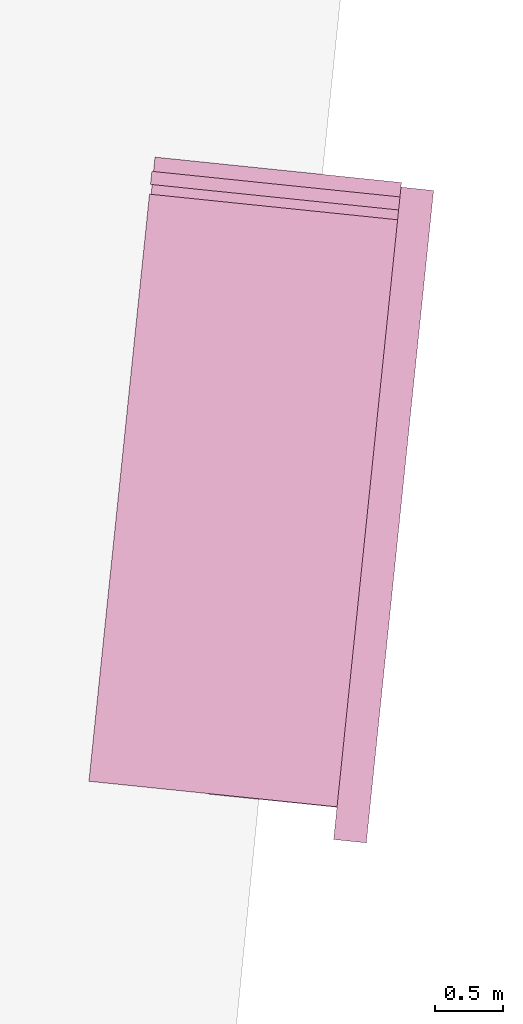
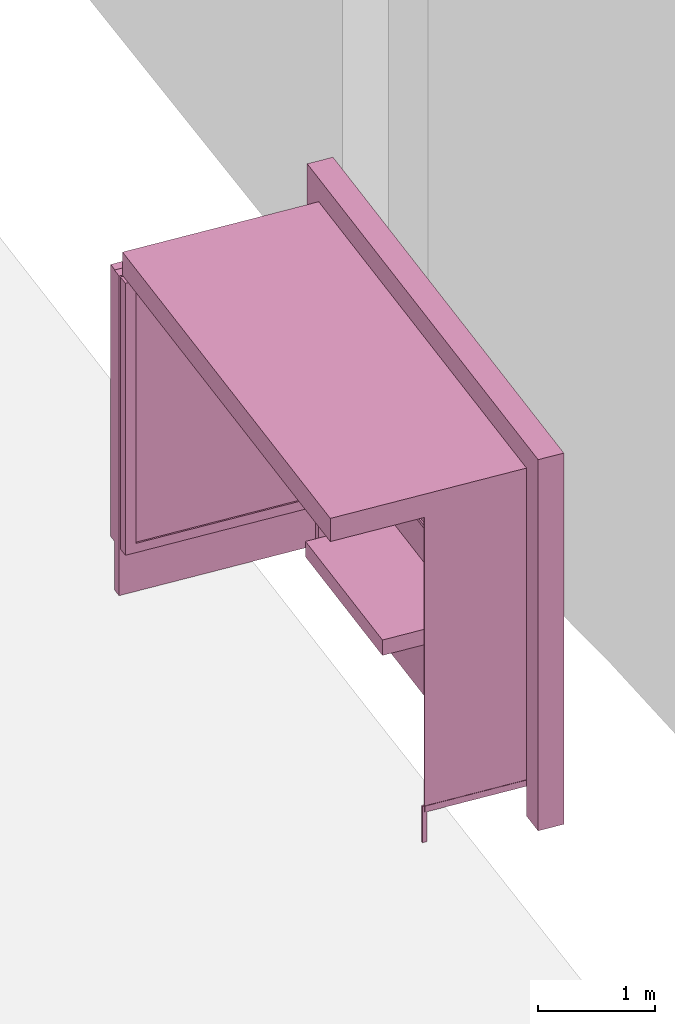
# One storey, part 12 of 200: 1 furnishing.
"""IFC4 building model written with IfcOpenShell, lengths in metres."""

from ifc_helpers import new_model, si_unit, origin_with_axes, place, context, subcontext, project, spatial, triangles, material, element, save


model = new_model("IFC4")

# Units and contexts
model_context = context("Model", 3, precision=1e-05, world=origin_with_axes())
body_context = subcontext(model_context, "Body", "Model", "MODEL_VIEW")
ifc_project = project(units=[si_unit("VOLUMEUNIT", "CUBIC_METRE"), si_unit("LENGTHUNIT", "METRE"), si_unit("AREAUNIT", "SQUARE_METRE")], contexts=[model_context])

# Site, building, storey
site_placement = place(None, origin_with_axes())
site = spatial("IfcSite", under=ifc_project, at=site_placement)
building_placement = place(site_placement, origin_with_axes())
building = spatial("IfcBuilding", under=site, at=building_placement, Name="Building")
storey_placement = place(building_placement, origin_with_axes())
storey = spatial("IfcBuildingStorey", under=building, at=storey_placement, Name="Ground")

# Furnishing
ifc_material = material(Name="busStop")
furnishing_placement = place(storey_placement, origin_with_axes())
element("IfcFurnishingElement", 1, at=furnishing_placement, inside=storey, material=ifc_material, Name="cw_instances_busStop_31", context=body_context, shape_type="Tessellation", body=[
    triangles([(370.17705950361335, -660.5963366665247, 3.3826375611235573), (371.7952975416118, -665.1250745815855, 3.3826375611235573), (372.2406078462146, -660.8092568819388, 3.3826375611235573), (369.7317489730696, -664.9121545205603, 3.3826375611235573), (370.1770594077063, -660.596336656629, 3.6236783199298275), (371.7952974457047, -665.1250745716898, 3.6236783199298275), (369.73174887716254, -664.9121545106645, 3.6236783199298275), (372.2406077503075, -660.8092568720431, 3.6236783199298275), (370.17705950361335, -660.5963366665247, 3.3826375611235573), (369.73174887716254, -664.9121545106645, 3.6236783199298275), (369.7317489730696, -664.9121545205603, 3.3826375611235573), (370.1770594077063, -660.596336656629, 3.6236783199298275), (369.7317489730696, -664.9121545205603, 3.3826375611235573), (371.7952974457047, -665.1250745716898, 3.6236783199298275), (371.7952975416118, -665.1250745815855, 3.3826375611235573), (369.73174887716254, -664.9121545106645, 3.6236783199298275), (371.7952975416118, -665.1250745815855, 3.3826375611235573), (372.2406077503075, -660.8092568720431, 3.6236783199298275), (372.2406078462146, -660.8092568819388, 3.3826375611235573), (371.7952974457047, -665.1250745716898, 3.6236783199298275), (372.2406078462146, -660.8092568819388, 3.3826375611235573), (370.1770594077063, -660.596336656629, 3.6236783199298275), (370.17705950361335, -660.5963366665247, 3.3826375611235573), (372.2406077503075, -660.8092568720431, 3.6236783199298275), (372.0008397530302, -660.7845174277934, 3.864718677001767), (372.26534680877126, -660.5694890126616, 3.864718677001767), (372.24060738266377, -660.8092568341093, 3.864718677001767), (372.02557917913765, -660.5447496063457, 3.864718677001767), (372.0008397530302, -660.7845174277934, 3.6236783199298275), (372.02557917913765, -660.5447496063457, 3.864718677001767), (372.0008397530302, -660.7845174277934, 3.864718677001767), (372.02557917913765, -660.5447496063457, 3.6236783199298275), (371.5307898359621, -665.3401027196483, 3.6236783199298275), (371.77055765740977, -665.3648421457558, 3.864718677001767), (371.77055765740977, -665.3648421457558, 3.6236783199298275), (371.5307898359621, -665.3401027196483, 3.864718677001767), (371.79529706207643, -665.1250745321067, 3.6236783199298275), (371.77055765740977, -665.3648421457558, 3.864718677001767), (371.79529706207643, -665.1250745321067, 3.864718677001767), (371.77055765740977, -665.3648421457558, 3.6236783199298275), (372.26534698460085, -660.5694890308039, 3.6236783199298275), (372.02557917913765, -660.5447496063457, 3.864718677001767), (372.02557917913765, -660.5447496063457, 3.6236783199298275), (372.26534680877126, -660.5694890126616, 3.864718677001767), (371.5555294324429, -665.1003351257908, 3.864718677001767), (371.79529706207643, -665.1250745321067, 3.864718677001767), (371.5555294324429, -665.1003351257908, 3.6236783199298275), (371.5555294324429, -665.1003351257908, 3.864718677001767), (372.26534698460085, -660.5694890308039, 3.6236783199298275), (372.24060738266377, -660.8092568341093, 3.864718677001767), (372.26534680877126, -660.5694890126616, 3.864718677001767), (372.24060738266377, -660.8092568341093, 3.6236783199298275), (371.5307898359621, -665.3401027196483, 3.864718677001767), (371.77055765740977, -665.3648421457558, 3.864718677001767), (371.5307898359621, -665.3401027196483, 3.6236783199298275), (371.5307898359621, -665.3401027196483, 3.864718677001767), (372.2653478477645, -660.5694891198657, 9.480930192426488e-07), (372.02558031403794, -660.5447497234455, 8.998848996201414e-07), (372.240608421657, -660.8092569413135, 9.480930192426488e-07), (372.2653478477645, -660.5694891198657, 9.480930192426488e-07), (372.24060738266377, -660.8092568341093, 3.6236783199298275), (372.00084071210085, -660.7845175267511, 8.998848996201414e-07), (372.0008397530302, -660.7845174277934, 3.6236783199298275), (372.240608421657, -660.8092569413135, 9.480930192426488e-07), (372.02558031403794, -660.5447497234455, 8.998848996201414e-07), (372.00084071210085, -660.7845175267511, 8.998848996201414e-07), (371.53079114352977, -665.340101319869, 8.998848996201414e-07), (371.770558696403, -665.3648422529599, 9.480930192426488e-07), (371.55553054984574, -665.1003336902354, 8.998848996201414e-07), (371.53079114352977, -665.340101319869, 8.998848996201414e-07), (371.5555294324429, -665.1003351257908, 3.6236783199298275), (371.7952982594018, -665.1250731047978, 9.480930192426488e-07), (371.79529706207643, -665.1250745321067, 3.6236783199298275), (371.55553054984574, -665.1003336902354, 8.998848996201414e-07), (371.770558696403, -665.3648422529599, 9.480930192426488e-07), (371.7952982594018, -665.1250731047978, 9.480930192426488e-07), (370.60916941161054, -665.0024370793218, 0.3459945917589383), (371.6499156172004, -665.1098220640723, 3.3826375611235573), (371.649916480364, -665.1098221531342, 0.34599476852204364), (370.6091686283695, -665.0024369985064, 3.3826375611235573), (371.651565772689, -665.0938376583453, 0.34599476852204364), (370.6108179206945, -664.9864525037174, 3.3826375611235573), (370.61081870393554, -664.9864525845328, 0.3459945917589383), (371.65156490952546, -665.0938375692833, 3.3826375611235573), (370.61081870393554, -664.9864525845328, 0.3459945917589383), (370.6091686283695, -665.0024369985064, 3.3826375611235573), (370.60916941161054, -665.0024370793218, 0.3459945917589383), (370.6108179206945, -664.9864525037174, 3.3826375611235573), (371.6519781060784, -665.0898414347448, 0.313856054245785), (370.60875714596625, -665.006433116056, 0.3138558614133065), (371.6495041667662, -665.1138181849205, 0.313856054245785), (370.6112310852784, -664.9824563658802, 0.3138558614133065), (371.6519781060784, -665.0898414347448, 0.37813349886767544), (370.6087571299817, -665.0064331144067, 0.37813330603519696), (370.6112310692939, -664.982456364231, 0.37813330603519696), (371.6495041667662, -665.1138181849205, 0.37813349886767544), (371.6519781060784, -665.0898414347448, 0.313856054245785), (370.6112310692939, -664.982456364231, 0.37813330603519696), (370.6112310852784, -664.9824563658802, 0.3138558614133065), (371.6519781060784, -665.0898414347448, 0.37813349886767544), (370.60875714596625, -665.006433116056, 0.3138558614133065), (371.6495041667662, -665.1138181849205, 0.37813349886767544), (371.6495041667662, -665.1138181849205, 0.313856054245785), (370.6087571299817, -665.0064331144067, 0.37813330603519696), (370.6087571299817, -665.0064331144067, 0.37813330603519696), (370.6112310852784, -664.9824563658802, 0.3138558614133065), (370.6112310692939, -664.982456364231, 0.37813330603519696), (370.60875714596625, -665.006433116056, 0.3138558614133065), (370.58883727865003, -664.983896809399, 0.37813330603519696), (370.631150969224, -665.0049909457017, 0.37813330603519696), (370.5871294347396, -665.000448770305, 0.37813330603519696), (370.63285881313436, -664.9884389847957, 0.37813330603519696), (370.58883753440216, -664.9838968357876, 1.446243588675227e-07), (370.5871294347396, -665.000448770305, 0.37813330603519696), (370.5871296904918, -665.0004487966936, 1.446243588675227e-07), (370.58883727865003, -664.983896809399, 0.37813330603519696), (370.5871296904918, -665.0004487966936, 1.446243588675227e-07), (370.631150969224, -665.0049909457017, 0.37813330603519696), (370.63115108111555, -665.0049909572467, 1.6069373207502523e-07), (370.5871294347396, -665.000448770305, 0.37813330603519696), (370.63115108111555, -665.0049909572467, 1.6069373207502523e-07), (370.63285881313436, -664.9884389847957, 0.37813330603519696), (370.63285892502597, -664.9884389963407, 1.6069373207502523e-07), (370.631150969224, -665.0049909457017, 0.37813330603519696), (370.63285892502597, -664.9884389963407, 1.6069373207502523e-07), (370.58883727865003, -664.983896809399, 0.37813330603519696), (370.58883753440216, -664.9838968357876, 1.446243588675227e-07), (370.63285881313436, -664.9884389847957, 0.37813330603519696), (371.80125470557203, -662.0774311563895, 1.1248564780513874), (371.7889513152917, -663.6916303011961, 1.1248565744676267), (371.63632482860646, -663.6758821842612, 1.1248564780513874), (371.9538810004431, -662.0931792535329, 1.1248565744676267), (371.63632502042054, -663.6758822040528, 4.981505694325782e-07), (371.80125470557203, -662.0774311563895, 0.964162810253855), (371.63632482860646, -663.6758821842612, 0.964162810253855), (371.80125504124675, -662.0774311910246, 4.981505694325782e-07), (371.7889516989199, -663.6916303407792, 5.302893158475833e-07), (371.63632482860646, -663.6758821842612, 0.964162810253855), (371.7889513152917, -663.6916303011961, 0.9641629066700942), (371.63632502042054, -663.6758822040528, 4.981505694325782e-07), (371.9538813840714, -662.0931792931159, 5.302893158475833e-07), (371.7889513152917, -663.6916303011961, 0.9641629066700942), (371.9538810004431, -662.0931792535329, 0.9641629066700942), (371.7889516989199, -663.6916303407792, 5.302893158475833e-07), (371.80125504124675, -662.0774311910246, 4.981505694325782e-07), (371.9538810004431, -662.0931792535329, 0.9641629066700942), (371.80125470557203, -662.0774311563895, 0.964162810253855), (371.9538813840714, -662.0931792931159, 5.302893158475833e-07), (370.99694446160424, -663.6099104318863, 1.124856381635148), (371.1618742586473, -662.011459395768, 0.9641627138376155), (371.16187422667826, -662.0114593924694, 1.124856381635148), (370.9969444775887, -663.6099104335356, 0.9641627138376155), (371.7889513152917, -663.6916303011961, 1.1248565744676267), (371.63632482860646, -663.6758821842612, 1.1248564780513874), (371.9538810004431, -662.0931792535329, 1.1248565744676267), (371.7889513152917, -663.6916303011961, 1.1248565744676267), (371.80125470557203, -662.0774311563895, 1.1248564780513874), (371.9538810004431, -662.0931792535329, 1.1248565744676267), (371.16187422667826, -662.0114593924694, 1.124856381635148), (370.99694446160424, -663.6099104318863, 1.124856381635148), (371.1618742586473, -662.011459395768, 0.9641627138376155), (371.16187422667826, -662.0114593924694, 1.124856381635148), (370.99694446160424, -663.6099104318863, 1.124856381635148), (370.9969444775887, -663.6099104335356, 0.9641627138376155), (372.101544433871, -660.6544931834381, 0.34599476852204364), (371.6295278530457, -665.2291305500545, 3.503157940526693), (371.62952879613186, -665.2291306473629, 0.34599476852204364), (372.1015437625216, -660.6544931141677, 3.503157940526693), (371.6455133069054, -665.2307799413372, 0.34599476852204364), (372.1175282573106, -660.6561424064928, 3.503157940526693), (372.11752892866, -660.6561424757631, 0.34599476852204364), (371.6455123478347, -665.2307798423795, 3.503157940526693), (371.93149742930837, -660.5171735622599, 0.5810001600002933), (370.31172368593536, -660.3500440759383, 3.2193552137185355), (370.3117242613777, -660.3500441353129, 0.5809998707515756), (371.9314968218969, -660.5171734995868, 3.2193552137185355), (372.0290537862744, -660.5110848313168, 0.4845839046859049), (370.3133735537027, -660.334059640524, 0.5809998707515756), (370.2174667416517, -660.3241623680453, 0.48458358329844076), (371.93314672163336, -660.5011890674709, 0.5810001600002933), (370.31337297826036, -660.3340595811493, 3.2193552137185355), (370.2174657218052, -660.3241637975119, 3.3157713565473115), (371.9331461142219, -660.5011890047978, 3.2193552137185355), (372.02905313090946, -660.5110847636957, 3.3157713565473115), (371.93314672163336, -660.5011890674709, 0.5810001600002933), (370.3117242613777, -660.3500441353129, 0.5809998707515756), (370.3133735537027, -660.334059640524, 0.5809998707515756), (371.93149742930837, -660.5171735622599, 0.5810001600002933), (370.3133735537027, -660.334059640524, 0.5809998707515756), (370.31172368593536, -660.3500440759383, 3.2193552137185355), (370.31337297826036, -660.3340595811493, 3.2193552137185355), (370.3117242613777, -660.3500441353129, 0.5809998707515756), (370.31337297826036, -660.3340595811493, 3.2193552137185355), (371.9314968218969, -660.5171734995868, 3.2193552137185355), (371.9331461142219, -660.5011890047978, 3.2193552137185355), (370.31172368593536, -660.3500440759383, 3.2193552137185355), (371.9331461142219, -660.5011890047978, 3.2193552137185355), (371.93149742930837, -660.5171735622599, 0.5810001600002933), (371.93314672163336, -660.5011890674709, 0.5810001600002933), (371.9314968218969, -660.5171734995868, 3.2193552137185355), (370.1857791594107, -660.6312613834257, 3.3157713565473115), (372.02905313090946, -660.5110847636957, 3.3157713565473115), (371.99736628079376, -660.8181823199221, 3.3157713565473115), (370.2174657218052, -660.3241637975119, 3.3157713565473115), (370.18578002257425, -660.6312614724876, 0.48458358329844076), (370.2174657218052, -660.3241637975119, 3.3157713565473115), (370.1857791594107, -660.6312613834257, 3.3157713565473115), (370.2174667416517, -660.3241623680453, 0.48458358329844076), (372.0290537862744, -660.5110848313168, 0.4845839046859049), (371.99736628079376, -660.8181823199221, 3.3157713565473115), (372.02905313090946, -660.5110847636957, 3.3157713565473115), (371.99736704805025, -660.8181823990883, 0.4845839046859049), (371.90310930770323, -660.7923021437521, 0.5810001600002933), (370.28333570819086, -660.6251726722741, 3.2193552137185355), (371.9031085084777, -660.7923020612874, 3.2193552137185355), (370.2833362836332, -660.6251727316486, 0.5809998707515756), (371.99736704805025, -660.8181823990883, 0.4845839046859049), (370.2816869913082, -660.6411572264376, 0.5809998707515756), (371.90146001537823, -660.8082866385411, 0.5810001600002933), (370.18578002257425, -660.6312614724876, 0.48458358329844076), (370.28168641586586, -660.641157167063, 3.2193552137185355), (370.1857791594107, -660.6312613834257, 3.3157713565473115), (371.9014592161527, -660.8082865560764, 3.2193552137185355), (371.99736628079376, -660.8181823199221, 3.3157713565473115), (371.90146001537823, -660.8082866385411, 0.5810001600002933), (370.2833362836332, -660.6251727316486, 0.5809998707515756), (371.90310930770323, -660.7923021437521, 0.5810001600002933), (370.2816869913082, -660.6411572264376, 0.5809998707515756), (370.2816869913082, -660.6411572264376, 0.5809998707515756), (370.28333570819086, -660.6251726722741, 3.2193552137185355), (370.2833362836332, -660.6251727316486, 0.5809998707515756), (370.28168641586586, -660.641157167063, 3.2193552137185355), (370.28168641586586, -660.641157167063, 3.2193552137185355), (371.9031085084777, -660.7923020612874, 3.2193552137185355), (370.28333570819086, -660.6251726722741, 3.2193552137185355), (371.9014592161527, -660.8082865560764, 3.2193552137185355), (371.9014592161527, -660.8082865560764, 3.2193552137185355), (371.90310930770323, -660.7923021437521, 0.5810001600002933), (371.9031085084777, -660.7923020612874, 3.2193552137185355), (371.90146001537823, -660.8082866385411, 0.5810001600002933), (370.19437691716763, -660.4285009817766, 3.3287619342644956), (372.00826197273716, -660.7125870410196, 3.3287619342644956), (370.1844813199005, -660.524406431982, 3.3287619342644956), (372.0181577266872, -660.6166800722856, 3.3287619342644956), (370.19437776499154, -660.4284993407043, 0.0), (370.1844813199005, -660.524406431982, 3.3287619342644956), (370.18448199125, -660.5244065012524, 0.0), (370.19437691716763, -660.4285009817766, 3.3287619342644956), (370.18448199125, -660.5244065012524, 0.0), (372.00826197273716, -660.7125870410196, 3.3287619342644956), (372.00826272400917, -660.7125871185364, 5.142199426400808e-07), (370.1844813199005, -660.524406431982, 3.3287619342644956), (372.00826272400917, -660.7125871185364, 5.142199426400808e-07), (372.0181577266872, -660.6166800722856, 3.3287619342644956), (372.0181584779592, -660.6166801498024, 5.142199426400808e-07), (372.00826197273716, -660.7125870410196, 3.3287619342644956), (372.0181584779592, -660.6166801498024, 5.142199426400808e-07), (370.19437691716763, -660.4285009817766, 3.3287619342644956), (370.19437776499154, -660.4284993407043, 0.0), (372.0181577266872, -660.6166800722856, 3.3287619342644956), (372.09754830617766, -660.6540808599445, 0.313856054245785), (371.6597217729329, -665.1322178287722, 0.313856054245785), (372.12152515226046, -660.6565548091525, 0.313856054245785), (371.6357450387417, -665.1297438911095, 0.313856054245785), (372.09754830617766, -660.6540808599445, 0.37813349886767544), (371.6597217729329, -665.1322178287722, 0.37813349886767544), (371.6357450387417, -665.1297438911095, 0.37813349886767544), (372.12152515226046, -660.6565548091525, 0.37813349886767544), (372.09754830617766, -660.6540808599445, 0.313856054245785), (371.6357450387417, -665.1297438911095, 0.37813349886767544), (371.6357450387417, -665.1297438911095, 0.313856054245785), (372.09754830617766, -660.6540808599445, 0.37813349886767544), (371.6597217729329, -665.1322178287722, 0.313856054245785), (372.12152515226046, -660.6565548091525, 0.37813349886767544), (372.12152515226046, -660.6565548091525, 0.313856054245785), (371.6597217729329, -665.1322178287722, 0.37813349886767544), (371.93648261656205, -662.2529314214939, 1.5290613779533648), (371.8045384256191, -663.5316922300885, 2.8146110577904615), (371.9364822329338, -662.2529313819109, 2.8146110577904615), (371.80453880924733, -663.5316922696717, 1.5290613779533648), (371.91974803863485, -662.2835141235346, 1.5612002850621018), (371.7944010428722, -663.4983368587154, 2.7824723435142027), (371.7944016023301, -663.4983369164407, 1.5612002850621018), (371.9197478468207, -662.283514103743, 2.7824723435142027), (371.93648261656205, -662.2529314214939, 1.5290613779533648), (371.775118326129, -663.5286566418557, 1.5290613779533648), (371.80453880924733, -663.5316922696717, 1.5290613779533648), (371.90706232525787, -662.2498958134695, 1.5290613779533648), (371.80453880924733, -663.5316922696717, 1.5290613779533648), (371.7751181502994, -663.5286566237135, 2.8146110577904615), (371.8045384256191, -663.5316922300885, 2.8146110577904615), (371.775118326129, -663.5286566418557, 1.5290613779533648), (371.8045384256191, -663.5316922300885, 2.8146110577904615), (371.90706194162965, -662.2498957738865, 2.8146110577904615), (371.9364822329338, -662.2529313819109, 2.8146110577904615), (371.7751181502994, -663.5286566237135, 2.8146110577904615), (371.9364822329338, -662.2529313819109, 2.8146110577904615), (371.90706232525787, -662.2498958134695, 1.5290613779533648), (371.93648261656205, -662.2529314214939, 1.5290613779533648), (371.90706194162965, -662.2498957738865, 2.8146110577904615), (371.76602080029164, -663.9049983865432, 1.5290613779533648), (371.6835553244242, -664.7042239419594, 2.8146110577904615), (371.76602021495347, -663.9049984230757, 2.8146110577904615), (371.6835557080525, -664.7042239815424, 1.5290613779533648), (371.7492863993349, -663.9355812522359, 1.5612002850621018), (371.67341822445064, -664.6708686482272, 2.7824723435142027), (371.6734185121718, -664.6708686779144, 1.5612002850621018), (371.749285839877, -663.9355811945106, 2.7824723435142027), (371.76602080029164, -663.9049983865432, 1.5290613779533648), (371.6541354327328, -664.7011883751674, 1.5290613779533648), (371.6835557080525, -664.7042239815424, 1.5290613779533648), (371.7366003171733, -663.9019627587272, 1.5290613779533648), (371.6835557080525, -664.7042239815424, 1.5290613779533648), (371.6541350491045, -664.7011883355843, 2.8146110577904615), (371.6835553244242, -664.7042239419594, 2.8146110577904615), (371.6541354327328, -664.7011883751674, 1.5290613779533648), (371.6835553244242, -664.7042239419594, 2.8146110577904615), (371.73659993963383, -663.9019628167006, 2.8146110577904615), (371.76602021495347, -663.9049984230757, 2.8146110577904615), (371.6541350491045, -664.7011883355843, 2.8146110577904615), (371.76602021495347, -663.9049984230757, 2.8146110577904615), (371.7366003171733, -663.9019627587272, 1.5290613779533648), (371.76602080029164, -663.9049983865432, 1.5290613779533648), (371.73659993963383, -663.9019628167006, 2.8146110577904615), (371.90706232525787, -662.2498958134695, 1.5290613779533648), (371.778417011634, -663.4966876142199, 1.5612002850621018), (371.775118326129, -663.5286566418557, 1.5290613779533648), (371.90376373566, -662.281864851001, 1.5612002850621018), (371.77841673989735, -663.4966875861819, 2.7824723435142027), (371.7751181502994, -663.5286566237135, 2.8146110577904615), (371.9037633520317, -662.281864811418, 2.7824723435142027), (371.90706194162965, -662.2498957738865, 2.8146110577904615), (371.7366003171733, -663.9019627587272, 1.5290613779533648), (371.6574340173828, -664.6692193855894, 1.5612002850621018), (371.6541354327328, -664.7011883751674, 1.5290613779533648), (371.73330171273176, -663.9339319401194, 1.5612002850621018), (371.6574336337546, -664.6692193460063, 2.7824723435142027), (371.6541350491045, -664.7011883355843, 2.8146110577904615), (371.733301345088, -663.9339319021856, 2.7824723435142027), (371.73659993963383, -663.9019628167006, 2.8146110577904615), (371.90376373566, -662.281864851001, 1.5612002850621018), (371.7944016023301, -663.4983369164407, 1.5612002850621018), (371.778417011634, -663.4966876142199, 1.5612002850621018), (371.91974803863485, -662.2835141235346, 1.5612002850621018), (371.778417011634, -663.4966876142199, 1.5612002850621018), (371.7944010428722, -663.4983368587154, 2.7824723435142027), (371.77841673989735, -663.4966875861819, 2.7824723435142027), (371.7944016023301, -663.4983369164407, 1.5612002850621018), (371.77841673989735, -663.4966875861819, 2.7824723435142027), (371.9197478468207, -662.283514103743, 2.7824723435142027), (371.9037633520317, -662.281864811418, 2.7824723435142027), (371.7944010428722, -663.4983368587154, 2.7824723435142027), (371.9037633520317, -662.281864811418, 2.7824723435142027), (371.91974803863485, -662.2835141235346, 1.5612002850621018), (371.90376373566, -662.281864851001, 1.5612002850621018), (371.9197478468207, -662.283514103743, 2.7824723435142027), (371.73330171273176, -663.9339319401194, 1.5612002850621018), (371.6734185121718, -664.6708686779144, 1.5612002850621018), (371.6574340173828, -664.6692193855894, 1.5612002850621018), (371.7492863993349, -663.9355812522359, 1.5612002850621018), (371.6574340173828, -664.6692193855894, 1.5612002850621018), (371.67341822445064, -664.6708686482272, 2.7824723435142027), (371.6574336337546, -664.6692193460063, 2.7824723435142027), (371.6734185121718, -664.6708686779144, 1.5612002850621018), (371.6574336337546, -664.6692193460063, 2.7824723435142027), (371.749285839877, -663.9355811945106, 2.7824723435142027), (371.733301345088, -663.9339319021856, 2.7824723435142027), (371.67341822445064, -664.6708686482272, 2.7824723435142027), (371.733301345088, -663.9339319021856, 2.7824723435142027), (371.7492863993349, -663.9355812522359, 1.5612002850621018), (371.73330171273176, -663.9339319401194, 1.5612002850621018), (371.749285839877, -663.9355811945106, 2.7824723435142027)], [[1, 3, 2], [2, 4, 1], [5, 7, 6], [6, 8, 5], [9, 11, 10], [10, 12, 9], [13, 15, 14], [14, 16, 13], [17, 19, 18], [18, 20, 17], [21, 23, 22], [22, 24, 21], [25, 27, 26], [26, 28, 25], [29, 31, 30], [30, 32, 29], [33, 35, 34], [34, 36, 33], [37, 39, 38], [38, 40, 37], [41, 43, 42], [42, 44, 41], [45, 46, 27], [27, 25, 45], [47, 48, 31], [31, 29, 47], [49, 51, 50], [50, 52, 49], [52, 50, 39], [39, 37, 52], [53, 54, 46], [46, 45, 53], [55, 56, 48], [48, 47, 55], [43, 41, 57], [57, 58, 43], [49, 52, 59], [59, 60, 49], [61, 63, 62], [62, 64, 61], [29, 32, 65], [65, 66, 29], [35, 33, 67], [67, 68, 35], [55, 47, 69], [69, 70, 55], [71, 73, 72], [72, 74, 71], [37, 40, 75], [75, 76, 37], [77, 79, 78], [78, 80, 77], [81, 83, 82], [82, 84, 81], [85, 87, 86], [86, 88, 85], [89, 91, 90], [90, 92, 89], [93, 95, 94], [94, 96, 93], [97, 99, 98], [98, 100, 97], [101, 103, 102], [102, 104, 101], [105, 107, 106], [106, 108, 105], [109, 111, 110], [110, 112, 109], [113, 115, 114], [114, 116, 113], [117, 119, 118], [118, 120, 117], [121, 123, 122], [122, 124, 121], [125, 127, 126], [126, 128, 125], [129, 131, 130], [130, 132, 129], [133, 135, 134], [134, 136, 133], [137, 139, 138], [138, 140, 137], [141, 143, 142], [142, 144, 141], [145, 147, 146], [146, 148, 145], [149, 151, 150], [150, 152, 149], [153, 154, 138], [138, 139, 153], [155, 156, 142], [142, 143, 155], [157, 158, 146], [146, 147, 157], [131, 129, 159], [159, 160, 131], [157, 147, 161], [161, 162, 157], [138, 154, 163], [163, 164, 138], [165, 167, 166], [166, 168, 165], [169, 171, 170], [170, 172, 169], [173, 175, 174], [174, 176, 173], [177, 179, 178], [178, 180, 177], [179, 182, 181], [181, 178, 179], [182, 184, 183], [183, 181, 182], [184, 177, 180], [180, 183, 184], [185, 187, 186], [186, 188, 185], [189, 191, 190], [190, 192, 189], [193, 195, 194], [194, 196, 193], [197, 199, 198], [198, 200, 197], [201, 203, 202], [202, 204, 201], [205, 207, 206], [206, 208, 205], [209, 211, 210], [210, 212, 209], [213, 215, 214], [214, 216, 213], [217, 219, 218], [218, 220, 217], [220, 218, 221], [221, 222, 220], [222, 221, 223], [223, 224, 222], [224, 223, 219], [219, 217, 224], [225, 227, 226], [226, 228, 225], [229, 231, 230], [230, 232, 229], [233, 235, 234], [234, 236, 233], [237, 239, 238], [238, 240, 237], [241, 243, 242], [242, 244, 241], [245, 247, 246], [246, 248, 245], [249, 251, 250], [250, 252, 249], [253, 255, 254], [254, 256, 253], [257, 259, 258], [258, 260, 257], [261, 263, 262], [262, 264, 261], [265, 267, 266], [266, 268, 265], [269, 271, 270], [270, 272, 269], [273, 275, 274], [274, 276, 273], [277, 279, 278], [278, 280, 277], [281, 283, 282], [282, 284, 281], [285, 287, 286], [286, 288, 285], [289, 291, 290], [290, 292, 289], [293, 295, 294], [294, 296, 293], [297, 299, 298], [298, 300, 297], [301, 303, 302], [302, 304, 301], [305, 307, 306], [306, 308, 305], [309, 311, 310], [310, 312, 309], [313, 315, 314], [314, 316, 313], [317, 319, 318], [318, 320, 317], [321, 323, 322], [322, 324, 321], [325, 327, 326], [326, 328, 325], [327, 330, 329], [329, 326, 327], [330, 332, 331], [331, 329, 330], [332, 325, 328], [328, 331, 332], [333, 335, 334], [334, 336, 333], [335, 338, 337], [337, 334, 335], [338, 340, 339], [339, 337, 338], [340, 333, 336], [336, 339, 340], [341, 343, 342], [342, 344, 341], [345, 347, 346], [346, 348, 345], [349, 351, 350], [350, 352, 349], [353, 355, 354], [354, 356, 353], [357, 359, 358], [358, 360, 357], [361, 363, 362], [362, 364, 361], [365, 367, 366], [366, 368, 365], [369, 371, 370], [370, 372, 369]], closed=True),
])

save(model, "model.ifc")
